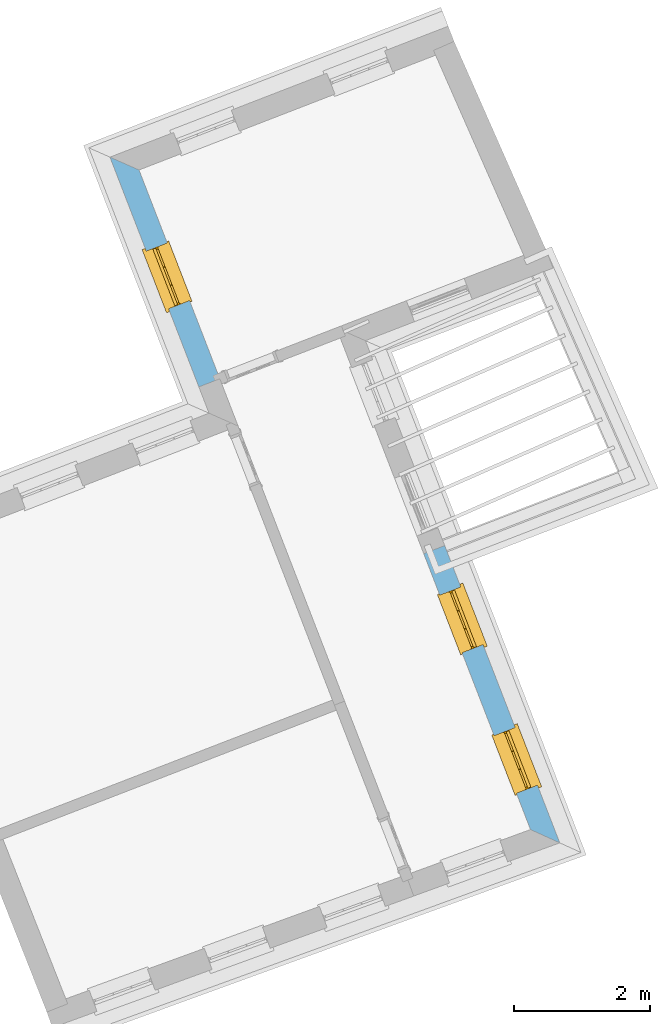
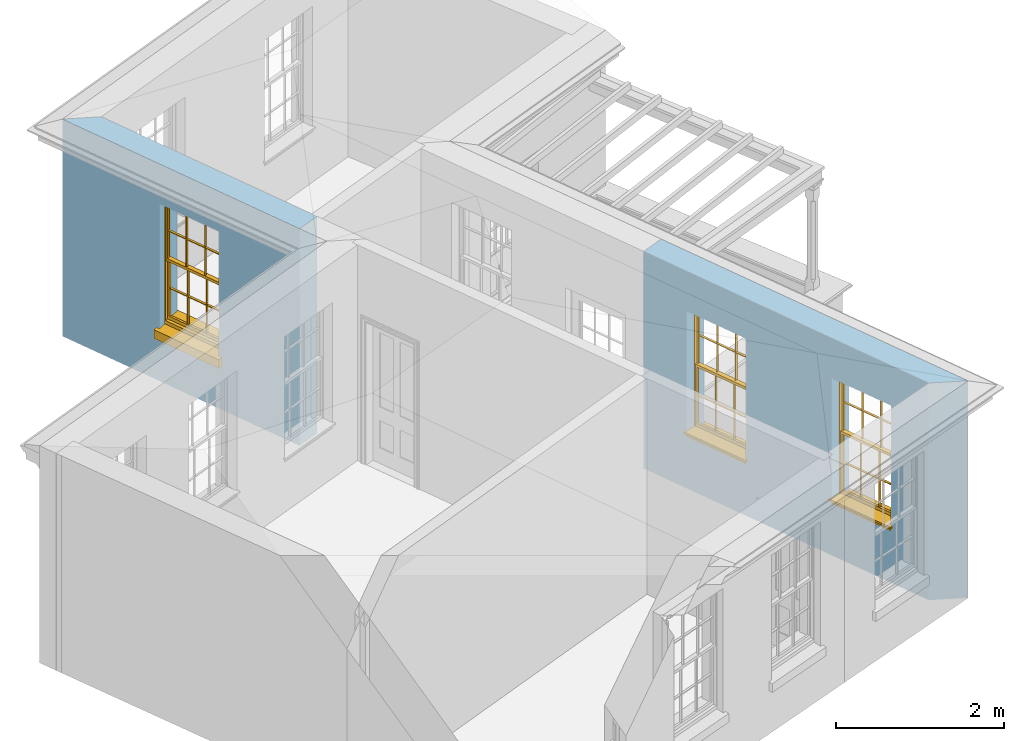
# One storey, part 7 of 11: 3 windows, 3 openings, plus 2 elements that do not belong to this part.
"""IFC2X3 building model written with IfcOpenShell, lengths in metres."""

from ifc_helpers import new_model, si_unit, frame, origin, place, context, subcontext, project, spatial, polyline, outline, extrude, faceted_brep, material, layer, layer_set, layer_usage, element, fill, save


model = new_model("IFC2X3")

# Units and contexts
model_context = context("Model", 3, world=origin())
body_context = subcontext(model_context, "Body", "Model", "MODEL_VIEW")
ifc_project = project(units=[si_unit("PLANEANGLEUNIT", "RADIAN"), si_unit("MASSUNIT", "GRAM", prefix="KILO"), si_unit("FORCEUNIT", "NEWTON", prefix="KILO"), si_unit("LENGTHUNIT", "METRE")], contexts=[model_context])

# Site, building, storey
site_placement = place(None, origin())
site = spatial("IfcSite", under=ifc_project, at=site_placement, CompositionType="ELEMENT")
building_placement = place(None, origin())
building = spatial("IfcBuilding", under=site, at=building_placement, Name="Building plot-5", CompositionType="ELEMENT")
storey_placement = place(None, frame((0.0, 0.0, 7.6)))
storey = spatial("IfcBuildingStorey", under=building, at=storey_placement, Name="Floor 1", CompositionType="ELEMENT", Elevation=7.6)

# Wall, opening, window
ifc_material = material(Name="Masonry")
ifc_layer = layer(ifc_material, 0.33, ventilated=False)
ifc_layer_set = layer_set([ifc_layer], Name="My Wall")
ifc_layer_usage = layer_usage(ifc_layer_set, "AXIS2", "NEGATIVE", 0.08)
wall_1_placement = place(storey_placement, origin())
wall_1 = element("IfcWallStandardCase", 1, at=wall_1_placement, inside=storey, material=ifc_layer_usage, Name="exterior", context=body_context, shape_type="SweptSolid", body=[
    extrude(outline(polyline([(58.9331084648426, 61.6885763134421), (58.5062551056088, 61.8772458915696), (59.8129029443682, 58.5005604091481), (60.1206644130489, 58.6196522997012), (58.9331084648426, 61.6885763134421)])), origin(), (0.0, 0.0, 1.0), 3.15),
])
opening_1_placement = place(storey_placement, frame((0.0, 0.0, 0.75)))
opening_1 = element("IfcOpeningElement", 2, at=opening_1_placement, cuts=wall_1, Name="Opening", ObjectType="Opening", context=body_context, shape_type="SweptSolid", body=[
    extrude(outline(polyline([(59.0404871344353, 60.4966646190395), (59.3688920447486, 59.6479890538898), (59.6766535134293, 59.767080944443), (59.348248603116, 60.6157565095927), (59.0404871344353, 60.4966646190395)])), origin(), (0.0, 0.0, 1.0), 1.82),
])
window_1_placement = place(storey_placement, frame((59.2736397622237, 60.5868857482464, 0.75), z_axis=(0.0, 0.0, 1.0), x_axis=(0.328404910313267, -0.848675565149684, 0.0)))
window_1 = element("IfcWindow", 3, at=window_1_placement, inside=storey, Name="bedroom outside window", OverallHeight=1.82, OverallWidth=0.91, context=body_context, shape_type="Brep", held_by="IfcProductRepresentation", body=[
    faceted_brep([(0.033125, -0.105, 0.975209), (0.01, -0.105, 0.975209), (0.033125, -0.105, 1.376042), (0.876875, -0.105, 0.975209), (0.876875, -0.105, 1.376042), (0.9, -0.105, 0.975209), (0.876875, -0.105, 1.386042), (0.876875, -0.105, 1.786875), (0.9, -0.105, 1.81), (0.033125, -0.105, 1.786875), (0.033125, -0.105, 1.386042), (0.01, -0.105, 1.81), (0.876875, -0.135, 1.376042), (0.876875, -0.135, 0.975209), (0.9, -0.135, 0.937083), (0.033125, -0.135, 1.786875), (0.01, -0.135, 1.81), (0.033125, -0.135, 1.386042), (0.01, -0.135, 0.937083), (0.033125, -0.135, 0.975209), (0.033125, -0.135, 1.376042), (0.876875, -0.135, 1.786875), (0.876875, -0.135, 1.386042), (0.9, -0.135, 1.81), (0.033125, -0.105, 0.937083), (0.01, -0.105, 0.937083), (0.033125, -0.105, 0.53625), (0.876875, -0.105, 0.937083), (0.876875, -0.105, 0.53625), (0.9, -0.105, 0.937083), (0.876875, -0.105, 0.52625), (0.876875, -0.105, 0.125417), (0.9, -0.105, 0.077167), (0.033125, -0.105, 0.125417), (0.033125, -0.105, 0.52625), (0.01, -0.105, 0.077167), (-0.0425, -0.25, 0.01), (-0.0425, -0.3, 0.001667), (0.0, -0.25, 0.01), (0.9525, -0.25, 0.01), (0.91, -0.25, 0.01), (0.9525, -0.3, 0.001667), (-0.02, 0.08, 0.077167), (0.0, 0.08, 0.077167), (-0.02, 0.11, 0.077167), (0.0, -0.06, 0.077167), (0.01, -0.06, 0.077167), (0.91, -0.06, 0.077167), (0.91, 0.08, 0.077167), (0.9, -0.06, 0.077167), (0.93, 0.08, 0.077167), (0.93, 0.11, 0.077167), (0.01, -0.075, 0.975209), (0.9, -0.075, 0.975209), (0.876875, -0.075, 0.125417), (0.876875, -0.075, 0.52625), (0.9, -0.075, 0.077167), (0.876875, -0.075, 0.53625), (0.876875, -0.075, 0.937083), (0.033125, -0.075, 0.125417), (0.01, -0.075, 0.077167), (0.033125, -0.075, 0.52625), (0.033125, -0.075, 0.937083), (0.033125, -0.075, 0.53625), (-0.02, 0.08, 0.052167), (-0.02, 0.11, 0.052167), (0.93, 0.11, 0.052167), (0.93, 0.08, 0.052167), (0.91, 0.08, 0.052167), (0.0, 0.08, 0.052167), (0.91, -0.15, 0.026667), (0.0, -0.15, 0.026667), (-0.0425, -0.3, -0.123333), (0.9525, -0.3, -0.123333), (-0.0425, -0.25, -0.123333), (0.9525, -0.25, -0.123333), (0.01, -0.06, 1.81), (0.9, -0.06, 1.81), (0.0, -0.06, 1.82), (0.91, -0.06, 1.82), (0.01, -0.15, 0.077167), (0.9, -0.15, 0.077167), (0.592292, -0.105, 0.125417), (0.592292, -0.075, 0.125417), (0.317708, -0.075, 0.125417), (0.317708, -0.105, 0.125417), (0.592292, -0.105, 0.53625), (0.317708, -0.105, 0.53625), (0.317708, -0.105, 0.52625), (0.592292, -0.105, 0.52625), (0.592292, -0.075, 0.53625), (0.317708, -0.075, 0.53625), (0.592292, -0.135, 1.386042), (0.592292, -0.105, 1.386042), (0.317708, -0.105, 1.386042), (0.317708, -0.135, 1.386042), (0.317708, -0.135, 1.376042), (0.592292, -0.135, 1.376042), (0.317708, -0.105, 1.376042), (0.592292, -0.105, 1.376042), (0.602292, -0.135, 1.376042), (0.592292, -0.135, 0.975209), (0.602292, -0.135, 0.975209), (0.602292, -0.105, 0.975209), (0.592292, -0.105, 0.975209), (0.602292, -0.105, 1.376042), (0.602292, -0.075, 0.53625), (0.602292, -0.105, 0.53625), (0.317708, -0.075, 0.52625), (0.307708, -0.075, 0.125417), (0.307708, -0.075, 0.52625), (0.602292, -0.075, 0.52625), (0.602292, -0.075, 0.125417), (0.592292, -0.075, 0.52625), (0.307708, -0.075, 0.53625), (0.317708, -0.075, 0.937083), (0.307708, -0.075, 0.937083), (0.602292, -0.075, 0.937083), (0.592292, -0.075, 0.937083), (0.307708, -0.105, 0.52625), (0.307708, -0.105, 0.125417), (0.307708, -0.105, 0.53625), (0.307708, -0.105, 0.937083), (0.592292, -0.105, 0.937083), (0.317708, -0.105, 0.937083), (0.602292, -0.105, 0.937083), (0.602292, -0.105, 0.52625), (0.602292, -0.105, 0.125417), (0.307708, -0.135, 1.386042), (0.307708, -0.135, 1.376042), (0.307708, -0.135, 0.975209), (0.317708, -0.135, 0.975209), (0.317708, -0.135, 1.786875), (0.307708, -0.135, 1.786875), (0.602292, -0.135, 1.786875), (0.592292, -0.135, 1.786875), (0.602292, -0.135, 1.386042), (0.602292, -0.105, 1.386042), (0.307708, -0.105, 1.386042), (0.307708, -0.105, 1.786875), (0.317708, -0.105, 1.786875), (0.592292, -0.105, 1.786875), (0.602292, -0.105, 1.786875), (0.307708, -0.105, 1.376042), (0.317708, -0.105, 0.975209), (0.307708, -0.105, 0.975209), (0.91, -0.15, 1.82), (0.9, -0.15, 1.81), (0.01, -0.15, 1.81), (0.0, -0.15, 1.82), (0.91, -0.25, 0.0), (0.0, -0.25, 0.0), (0.91, 0.08, 0.0), (0.0, 0.08, 0.0)], [[[0, 1, 2]], [[3, 4, 5]], [[6, 7, 8]], [[9, 10, 11]], [[12, 13, 14]], [[15, 16, 17]], [[18, 19, 20]], [[21, 22, 23]], [[24, 25, 26]], [[27, 28, 29]], [[30, 31, 32]], [[33, 34, 35]], [[14, 27, 29]], [[25, 24, 18]], [[36, 37, 38]], [[39, 40, 41]], [[42, 43, 44]], [[45, 46, 43]], [[47, 48, 49]], [[50, 51, 48]], [[1, 0, 52]], [[5, 53, 3]], [[54, 55, 56]], [[57, 58, 53]], [[59, 60, 61]], [[62, 63, 52]], [[48, 43, 46, 49]], [[51, 44, 43, 48]], [[64, 42, 44, 65]], [[65, 44, 51, 66]], [[66, 51, 50, 67]], [[65, 66, 68, 69]], [[60, 56, 49, 46]], [[70, 71, 38, 40]], [[37, 41, 40, 38]], [[37, 72, 73, 41]], [[74, 75, 73, 72]], [[8, 11, 76, 77]], [[76, 78, 79, 77]], [[32, 35, 80, 81]], [[81, 80, 71, 70]], [[82, 83, 84, 85]], [[86, 87, 88, 89]], [[86, 90, 91, 87]], [[92, 93, 94, 95]], [[92, 95, 96, 97]], [[96, 98, 99, 97]], [[100, 97, 101, 102]], [[103, 104, 99, 105]], [[97, 99, 104, 101]], [[102, 103, 105, 100]], [[28, 57, 106, 107]], [[108, 84, 109, 110]], [[111, 112, 83, 113]], [[114, 110, 61, 63]], [[90, 113, 108, 91]], [[115, 91, 114, 116]], [[117, 106, 90, 118]], [[111, 106, 57, 55]], [[119, 110, 109, 120]], [[34, 61, 110, 119]], [[89, 113, 83, 82]], [[88, 108, 113, 89]], [[85, 84, 108, 88]], [[121, 114, 63, 26]], [[122, 116, 114, 121]], [[123, 118, 90, 86]], [[87, 91, 115, 124]], [[107, 106, 117, 125]], [[126, 111, 55, 30]], [[127, 112, 111, 126]], [[126, 30, 28, 107]], [[88, 119, 120, 85]], [[126, 89, 82, 127]], [[125, 123, 86, 107]], [[121, 26, 34, 119]], [[124, 122, 121, 87]], [[128, 17, 20, 129]], [[96, 129, 130, 131]], [[132, 133, 128, 95]], [[134, 135, 92, 136]], [[100, 12, 22, 136]], [[137, 6, 4, 105]], [[94, 138, 139, 140]], [[137, 93, 141, 142]], [[99, 98, 94, 93]], [[143, 2, 10, 138]], [[144, 145, 143, 98]], [[129, 143, 145, 130]], [[20, 2, 143, 129]], [[131, 144, 98, 96]], [[128, 138, 10, 17]], [[133, 139, 138, 128]], [[135, 141, 93, 92]], [[95, 94, 140, 132]], [[22, 6, 137, 136]], [[136, 137, 142, 134]], [[100, 105, 4, 12]], [[107, 86, 89, 126]], [[106, 111, 113, 90]], [[91, 108, 110, 114]], [[87, 121, 119, 88]], [[97, 100, 136, 92]], [[129, 96, 95, 128]], [[98, 143, 138, 94]], [[105, 99, 93, 137]], [[131, 101, 104, 144]], [[124, 115, 118, 123]], [[132, 140, 141, 135]], [[120, 109, 59, 33]], [[15, 9, 139, 133]], [[134, 142, 7, 21]], [[31, 54, 112, 127]], [[36, 74, 72, 37]], [[39, 41, 73, 75]], [[18, 14, 101, 131]], [[23, 16, 132, 135]], [[83, 56, 60, 84]], [[52, 53, 118, 115]], [[53, 52, 144, 104]], [[11, 8, 141, 140]], [[14, 18, 124, 123]], [[2, 1, 11, 10]], [[8, 5, 4, 6]], [[57, 53, 56, 55]], [[60, 52, 63, 61]], [[26, 25, 35, 34]], [[32, 29, 28, 30]], [[14, 23, 22, 12]], [[18, 20, 17, 16]], [[19, 0, 2, 20]], [[17, 10, 9, 15]], [[12, 4, 3, 13]], [[21, 7, 6, 22]], [[27, 58, 57, 28]], [[30, 55, 54, 31]], [[33, 59, 61, 34]], [[26, 63, 62, 24]], [[5, 8, 77, 53]], [[76, 11, 1, 52]], [[46, 45, 78, 76]], [[49, 77, 79, 47]], [[70, 146, 147, 81]], [[71, 80, 148, 149]], [[19, 130, 145, 0]], [[102, 13, 3, 103]], [[116, 122, 24, 62]], [[29, 32, 81, 14]], [[80, 35, 25, 18]], [[60, 46, 76, 52]], [[77, 49, 56, 53]], [[23, 14, 81, 147]], [[16, 148, 80, 18]], [[35, 85, 120]], [[120, 33, 35]], [[127, 82, 32]], [[32, 31, 127]], [[32, 82, 85, 35]], [[102, 101, 14]], [[14, 13, 102]], [[18, 131, 130]], [[130, 19, 18]], [[134, 21, 23]], [[23, 135, 134]], [[16, 15, 133]], [[133, 132, 16]], [[11, 140, 139]], [[139, 9, 11]], [[142, 141, 8]], [[8, 7, 142]], [[23, 147, 148, 16]], [[146, 149, 148, 147]], [[52, 115, 116]], [[116, 62, 52]], [[118, 53, 117]], [[58, 117, 53]], [[27, 125, 117, 58]], [[56, 83, 112]], [[112, 54, 56]], [[109, 84, 60]], [[60, 59, 109]], [[125, 27, 14]], [[14, 123, 125]], [[122, 124, 18]], [[18, 24, 122]], [[145, 144, 52]], [[52, 0, 145]], [[103, 3, 53]], [[53, 104, 103]], [[79, 78, 149, 146]], [[78, 45, 71, 149]], [[146, 70, 47, 79]], [[150, 75, 74, 151]], [[68, 66, 67]], [[48, 68, 67, 50]], [[69, 64, 65]], [[42, 64, 69, 43]], [[69, 68, 152, 153]], [[70, 68, 48, 47]], [[150, 152, 68, 70]], [[43, 69, 71, 45]], [[69, 153, 151, 71]], [[152, 150, 151, 153]], [[38, 151, 74, 36]], [[71, 151, 38]], [[39, 75, 150, 40]], [[40, 150, 70]]]),
])
fill(opening_1, window_1)

# Wall, openings, windows
wall_2_placement = place(storey_placement, origin())
wall_2 = element("IfcWallStandardCase", 4, at=wall_2_placement, inside=storey, material=ifc_layer_usage, Name="exterior", context=body_context, shape_type="SweptSolid", body=[
    extrude(outline(polyline([(64.6874687237686, 51.9939267924886), (65.1167215345807, 51.7990564668682), (63.4260314383826, 56.1681975114254), (63.1182699697019, 56.0491056208722), (64.6874687237686, 51.9939267924886)])), origin(), (0.0, 0.0, 1.0), 3.15),
])
opening_2_placement = place(storey_placement, frame((0.0, 0.0, 0.75)))
opening_2 = element("IfcOpeningElement", 5, at=opening_2_placement, cuts=wall_2, Name="Opening", ObjectType="Opening", context=body_context, shape_type="SweptSolid", body=[
    extrude(outline(polyline([(64.7892222940222, 52.6453915682585), (64.4608173837089, 53.4940671334082), (64.1530559150283, 53.374975242855), (64.4814608253416, 52.5262996777054), (64.7892222940222, 52.6453915682585)])), origin(), (0.0, 0.0, 1.0), 1.82),
])
opening_3_placement = place(storey_placement, frame((0.0, 0.0, 0.75)))
opening_3 = element("IfcOpeningElement", 6, at=opening_3_placement, cuts=wall_2, Name="Opening", ObjectType="Opening", context=body_context, shape_type="SweptSolid", body=[
    extrude(outline(polyline([(63.9898966937002, 54.7110370086532), (63.6614917833869, 55.5597125738029), (63.3537303147063, 55.4406206832497), (63.6821352250196, 54.5919451181), (63.9898966937002, 54.7110370086532)])), origin(), (0.0, 0.0, 1.0), 1.82),
])
window_2_placement = place(storey_placement, frame((64.5560696662338, 52.5551704390516, 0.75), z_axis=(0.0, 0.0, 1.0), x_axis=(-0.328404910313296, 0.848675565149676, 0.0)))
window_2 = element("IfcWindow", 7, at=window_2_placement, inside=storey, Name="circulation outside window", OverallHeight=1.82, OverallWidth=0.91, context=body_context, shape_type="Brep", held_by="IfcProductRepresentation", body=[
    faceted_brep([(0.033125, -0.105, 0.975209), (0.01, -0.105, 0.975209), (0.033125, -0.105, 1.376042), (0.876875, -0.105, 0.975209), (0.876875, -0.105, 1.376042), (0.9, -0.105, 0.975209), (0.876875, -0.105, 1.386042), (0.876875, -0.105, 1.786875), (0.9, -0.105, 1.81), (0.033125, -0.105, 1.786875), (0.033125, -0.105, 1.386042), (0.01, -0.105, 1.81), (0.876875, -0.135, 1.376042), (0.876875, -0.135, 0.975209), (0.9, -0.135, 0.937083), (0.033125, -0.135, 1.786875), (0.01, -0.135, 1.81), (0.033125, -0.135, 1.386042), (0.01, -0.135, 0.937083), (0.033125, -0.135, 0.975209), (0.033125, -0.135, 1.376042), (0.876875, -0.135, 1.786875), (0.876875, -0.135, 1.386042), (0.9, -0.135, 1.81), (0.033125, -0.105, 0.937083), (0.01, -0.105, 0.937083), (0.033125, -0.105, 0.53625), (0.876875, -0.105, 0.937083), (0.876875, -0.105, 0.53625), (0.9, -0.105, 0.937083), (0.876875, -0.105, 0.52625), (0.876875, -0.105, 0.125417), (0.9, -0.105, 0.077167), (0.033125, -0.105, 0.125417), (0.033125, -0.105, 0.52625), (0.01, -0.105, 0.077167), (-0.0425, -0.25, 0.01), (-0.0425, -0.3, 0.001667), (0.0, -0.25, 0.01), (0.9525, -0.25, 0.01), (0.91, -0.25, 0.01), (0.9525, -0.3, 0.001667), (-0.02, 0.08, 0.077167), (0.0, 0.08, 0.077167), (-0.02, 0.11, 0.077167), (0.0, -0.06, 0.077167), (0.01, -0.06, 0.077167), (0.91, -0.06, 0.077167), (0.91, 0.08, 0.077167), (0.9, -0.06, 0.077167), (0.93, 0.08, 0.077167), (0.93, 0.11, 0.077167), (0.01, -0.075, 0.975209), (0.9, -0.075, 0.975209), (0.876875, -0.075, 0.125417), (0.876875, -0.075, 0.52625), (0.9, -0.075, 0.077167), (0.876875, -0.075, 0.53625), (0.876875, -0.075, 0.937083), (0.033125, -0.075, 0.125417), (0.01, -0.075, 0.077167), (0.033125, -0.075, 0.52625), (0.033125, -0.075, 0.937083), (0.033125, -0.075, 0.53625), (-0.02, 0.08, 0.052167), (-0.02, 0.11, 0.052167), (0.93, 0.11, 0.052167), (0.93, 0.08, 0.052167), (0.91, 0.08, 0.052167), (0.0, 0.08, 0.052167), (0.91, -0.15, 0.026667), (0.0, -0.15, 0.026667), (-0.0425, -0.3, -0.123333), (0.9525, -0.3, -0.123333), (-0.0425, -0.25, -0.123333), (0.9525, -0.25, -0.123333), (0.01, -0.06, 1.81), (0.9, -0.06, 1.81), (0.0, -0.06, 1.82), (0.91, -0.06, 1.82), (0.01, -0.15, 0.077167), (0.9, -0.15, 0.077167), (0.592292, -0.105, 0.125417), (0.592292, -0.075, 0.125417), (0.317708, -0.075, 0.125417), (0.317708, -0.105, 0.125417), (0.592292, -0.105, 0.53625), (0.317708, -0.105, 0.53625), (0.317708, -0.105, 0.52625), (0.592292, -0.105, 0.52625), (0.592292, -0.075, 0.53625), (0.317708, -0.075, 0.53625), (0.592292, -0.135, 1.386042), (0.592292, -0.105, 1.386042), (0.317708, -0.105, 1.386042), (0.317708, -0.135, 1.386042), (0.317708, -0.135, 1.376042), (0.592292, -0.135, 1.376042), (0.317708, -0.105, 1.376042), (0.592292, -0.105, 1.376042), (0.602292, -0.135, 1.376042), (0.592292, -0.135, 0.975209), (0.602292, -0.135, 0.975209), (0.602292, -0.105, 0.975209), (0.592292, -0.105, 0.975209), (0.602292, -0.105, 1.376042), (0.602292, -0.075, 0.53625), (0.602292, -0.105, 0.53625), (0.317708, -0.075, 0.52625), (0.307708, -0.075, 0.125417), (0.307708, -0.075, 0.52625), (0.602292, -0.075, 0.52625), (0.602292, -0.075, 0.125417), (0.592292, -0.075, 0.52625), (0.307708, -0.075, 0.53625), (0.317708, -0.075, 0.937083), (0.307708, -0.075, 0.937083), (0.602292, -0.075, 0.937083), (0.592292, -0.075, 0.937083), (0.307708, -0.105, 0.52625), (0.307708, -0.105, 0.125417), (0.307708, -0.105, 0.53625), (0.307708, -0.105, 0.937083), (0.592292, -0.105, 0.937083), (0.317708, -0.105, 0.937083), (0.602292, -0.105, 0.937083), (0.602292, -0.105, 0.52625), (0.602292, -0.105, 0.125417), (0.307708, -0.135, 1.386042), (0.307708, -0.135, 1.376042), (0.307708, -0.135, 0.975209), (0.317708, -0.135, 0.975209), (0.317708, -0.135, 1.786875), (0.307708, -0.135, 1.786875), (0.602292, -0.135, 1.786875), (0.592292, -0.135, 1.786875), (0.602292, -0.135, 1.386042), (0.602292, -0.105, 1.386042), (0.307708, -0.105, 1.386042), (0.307708, -0.105, 1.786875), (0.317708, -0.105, 1.786875), (0.592292, -0.105, 1.786875), (0.602292, -0.105, 1.786875), (0.307708, -0.105, 1.376042), (0.317708, -0.105, 0.975209), (0.307708, -0.105, 0.975209), (0.91, -0.15, 1.82), (0.9, -0.15, 1.81), (0.01, -0.15, 1.81), (0.0, -0.15, 1.82), (0.91, -0.25, 0.0), (0.0, -0.25, 0.0), (0.91, 0.08, 0.0), (0.0, 0.08, 0.0)], [[[0, 1, 2]], [[3, 4, 5]], [[6, 7, 8]], [[9, 10, 11]], [[12, 13, 14]], [[15, 16, 17]], [[18, 19, 20]], [[21, 22, 23]], [[24, 25, 26]], [[27, 28, 29]], [[30, 31, 32]], [[33, 34, 35]], [[14, 27, 29]], [[25, 24, 18]], [[36, 37, 38]], [[39, 40, 41]], [[42, 43, 44]], [[45, 46, 43]], [[47, 48, 49]], [[50, 51, 48]], [[1, 0, 52]], [[5, 53, 3]], [[54, 55, 56]], [[57, 58, 53]], [[59, 60, 61]], [[62, 63, 52]], [[48, 43, 46, 49]], [[51, 44, 43, 48]], [[64, 42, 44, 65]], [[65, 44, 51, 66]], [[66, 51, 50, 67]], [[65, 66, 68, 69]], [[60, 56, 49, 46]], [[70, 71, 38, 40]], [[37, 41, 40, 38]], [[37, 72, 73, 41]], [[74, 75, 73, 72]], [[8, 11, 76, 77]], [[76, 78, 79, 77]], [[32, 35, 80, 81]], [[81, 80, 71, 70]], [[82, 83, 84, 85]], [[86, 87, 88, 89]], [[86, 90, 91, 87]], [[92, 93, 94, 95]], [[92, 95, 96, 97]], [[96, 98, 99, 97]], [[100, 97, 101, 102]], [[103, 104, 99, 105]], [[97, 99, 104, 101]], [[102, 103, 105, 100]], [[28, 57, 106, 107]], [[108, 84, 109, 110]], [[111, 112, 83, 113]], [[114, 110, 61, 63]], [[90, 113, 108, 91]], [[115, 91, 114, 116]], [[117, 106, 90, 118]], [[111, 106, 57, 55]], [[119, 110, 109, 120]], [[34, 61, 110, 119]], [[89, 113, 83, 82]], [[88, 108, 113, 89]], [[85, 84, 108, 88]], [[121, 114, 63, 26]], [[122, 116, 114, 121]], [[123, 118, 90, 86]], [[87, 91, 115, 124]], [[107, 106, 117, 125]], [[126, 111, 55, 30]], [[127, 112, 111, 126]], [[126, 30, 28, 107]], [[88, 119, 120, 85]], [[126, 89, 82, 127]], [[125, 123, 86, 107]], [[121, 26, 34, 119]], [[124, 122, 121, 87]], [[128, 17, 20, 129]], [[96, 129, 130, 131]], [[132, 133, 128, 95]], [[134, 135, 92, 136]], [[100, 12, 22, 136]], [[137, 6, 4, 105]], [[94, 138, 139, 140]], [[137, 93, 141, 142]], [[99, 98, 94, 93]], [[143, 2, 10, 138]], [[144, 145, 143, 98]], [[129, 143, 145, 130]], [[20, 2, 143, 129]], [[131, 144, 98, 96]], [[128, 138, 10, 17]], [[133, 139, 138, 128]], [[135, 141, 93, 92]], [[95, 94, 140, 132]], [[22, 6, 137, 136]], [[136, 137, 142, 134]], [[100, 105, 4, 12]], [[107, 86, 89, 126]], [[106, 111, 113, 90]], [[91, 108, 110, 114]], [[87, 121, 119, 88]], [[97, 100, 136, 92]], [[129, 96, 95, 128]], [[98, 143, 138, 94]], [[105, 99, 93, 137]], [[131, 101, 104, 144]], [[124, 115, 118, 123]], [[132, 140, 141, 135]], [[120, 109, 59, 33]], [[15, 9, 139, 133]], [[134, 142, 7, 21]], [[31, 54, 112, 127]], [[36, 74, 72, 37]], [[39, 41, 73, 75]], [[18, 14, 101, 131]], [[23, 16, 132, 135]], [[83, 56, 60, 84]], [[52, 53, 118, 115]], [[53, 52, 144, 104]], [[11, 8, 141, 140]], [[14, 18, 124, 123]], [[2, 1, 11, 10]], [[8, 5, 4, 6]], [[57, 53, 56, 55]], [[60, 52, 63, 61]], [[26, 25, 35, 34]], [[32, 29, 28, 30]], [[14, 23, 22, 12]], [[18, 20, 17, 16]], [[19, 0, 2, 20]], [[17, 10, 9, 15]], [[12, 4, 3, 13]], [[21, 7, 6, 22]], [[27, 58, 57, 28]], [[30, 55, 54, 31]], [[33, 59, 61, 34]], [[26, 63, 62, 24]], [[5, 8, 77, 53]], [[76, 11, 1, 52]], [[46, 45, 78, 76]], [[49, 77, 79, 47]], [[70, 146, 147, 81]], [[71, 80, 148, 149]], [[19, 130, 145, 0]], [[102, 13, 3, 103]], [[116, 122, 24, 62]], [[29, 32, 81, 14]], [[80, 35, 25, 18]], [[60, 46, 76, 52]], [[77, 49, 56, 53]], [[23, 14, 81, 147]], [[16, 148, 80, 18]], [[35, 85, 120]], [[120, 33, 35]], [[127, 82, 32]], [[32, 31, 127]], [[32, 82, 85, 35]], [[102, 101, 14]], [[14, 13, 102]], [[18, 131, 130]], [[130, 19, 18]], [[134, 21, 23]], [[23, 135, 134]], [[16, 15, 133]], [[133, 132, 16]], [[11, 140, 139]], [[139, 9, 11]], [[142, 141, 8]], [[8, 7, 142]], [[23, 147, 148, 16]], [[146, 149, 148, 147]], [[52, 115, 116]], [[116, 62, 52]], [[118, 53, 117]], [[58, 117, 53]], [[27, 125, 117, 58]], [[56, 83, 112]], [[112, 54, 56]], [[109, 84, 60]], [[60, 59, 109]], [[125, 27, 14]], [[14, 123, 125]], [[122, 124, 18]], [[18, 24, 122]], [[145, 144, 52]], [[52, 0, 145]], [[103, 3, 53]], [[53, 104, 103]], [[79, 78, 149, 146]], [[78, 45, 71, 149]], [[146, 70, 47, 79]], [[150, 75, 74, 151]], [[68, 66, 67]], [[48, 68, 67, 50]], [[69, 64, 65]], [[42, 64, 69, 43]], [[69, 68, 152, 153]], [[70, 68, 48, 47]], [[150, 152, 68, 70]], [[43, 69, 71, 45]], [[69, 153, 151, 71]], [[152, 150, 151, 153]], [[38, 151, 74, 36]], [[71, 151, 38]], [[39, 75, 150, 40]], [[40, 150, 70]]]),
])
fill(opening_2, window_2)
window_3_placement = place(storey_placement, frame((63.7567440659118, 54.6208158794462, 0.75), z_axis=(0.0, 0.0, 1.0), x_axis=(-0.328404910313296, 0.848675565149676, 0.0)))
window_3 = element("IfcWindow", 8, at=window_3_placement, inside=storey, Name="circulation outside window", OverallHeight=1.82, OverallWidth=0.91, context=body_context, shape_type="Brep", held_by="IfcProductRepresentation", body=[
    faceted_brep([(0.033125, -0.105, 0.975209), (0.01, -0.105, 0.975209), (0.033125, -0.105, 1.376042), (0.876875, -0.105, 0.975209), (0.876875, -0.105, 1.376042), (0.9, -0.105, 0.975209), (0.876875, -0.105, 1.386042), (0.876875, -0.105, 1.786875), (0.9, -0.105, 1.81), (0.033125, -0.105, 1.786875), (0.033125, -0.105, 1.386042), (0.01, -0.105, 1.81), (0.876875, -0.135, 1.376042), (0.876875, -0.135, 0.975209), (0.9, -0.135, 0.937083), (0.033125, -0.135, 1.786875), (0.01, -0.135, 1.81), (0.033125, -0.135, 1.386042), (0.01, -0.135, 0.937083), (0.033125, -0.135, 0.975209), (0.033125, -0.135, 1.376042), (0.876875, -0.135, 1.786875), (0.876875, -0.135, 1.386042), (0.9, -0.135, 1.81), (0.033125, -0.105, 0.937083), (0.01, -0.105, 0.937083), (0.033125, -0.105, 0.53625), (0.876875, -0.105, 0.937083), (0.876875, -0.105, 0.53625), (0.9, -0.105, 0.937083), (0.876875, -0.105, 0.52625), (0.876875, -0.105, 0.125417), (0.9, -0.105, 0.077167), (0.033125, -0.105, 0.125417), (0.033125, -0.105, 0.52625), (0.01, -0.105, 0.077167), (-0.0425, -0.25, 0.01), (-0.0425, -0.3, 0.001667), (0.0, -0.25, 0.01), (0.9525, -0.25, 0.01), (0.91, -0.25, 0.01), (0.9525, -0.3, 0.001667), (-0.02, 0.08, 0.077167), (0.0, 0.08, 0.077167), (-0.02, 0.11, 0.077167), (0.0, -0.06, 0.077167), (0.01, -0.06, 0.077167), (0.91, -0.06, 0.077167), (0.91, 0.08, 0.077167), (0.9, -0.06, 0.077167), (0.93, 0.08, 0.077167), (0.93, 0.11, 0.077167), (0.01, -0.075, 0.975209), (0.9, -0.075, 0.975209), (0.876875, -0.075, 0.125417), (0.876875, -0.075, 0.52625), (0.9, -0.075, 0.077167), (0.876875, -0.075, 0.53625), (0.876875, -0.075, 0.937083), (0.033125, -0.075, 0.125417), (0.01, -0.075, 0.077167), (0.033125, -0.075, 0.52625), (0.033125, -0.075, 0.937083), (0.033125, -0.075, 0.53625), (-0.02, 0.08, 0.052167), (-0.02, 0.11, 0.052167), (0.93, 0.11, 0.052167), (0.93, 0.08, 0.052167), (0.91, 0.08, 0.052167), (0.0, 0.08, 0.052167), (0.91, -0.15, 0.026667), (0.0, -0.15, 0.026667), (-0.0425, -0.3, -0.123333), (0.9525, -0.3, -0.123333), (-0.0425, -0.25, -0.123333), (0.9525, -0.25, -0.123333), (0.01, -0.06, 1.81), (0.9, -0.06, 1.81), (0.0, -0.06, 1.82), (0.91, -0.06, 1.82), (0.01, -0.15, 0.077167), (0.9, -0.15, 0.077167), (0.592292, -0.105, 0.125417), (0.592292, -0.075, 0.125417), (0.317708, -0.075, 0.125417), (0.317708, -0.105, 0.125417), (0.592292, -0.105, 0.53625), (0.317708, -0.105, 0.53625), (0.317708, -0.105, 0.52625), (0.592292, -0.105, 0.52625), (0.592292, -0.075, 0.53625), (0.317708, -0.075, 0.53625), (0.592292, -0.135, 1.386042), (0.592292, -0.105, 1.386042), (0.317708, -0.105, 1.386042), (0.317708, -0.135, 1.386042), (0.317708, -0.135, 1.376042), (0.592292, -0.135, 1.376042), (0.317708, -0.105, 1.376042), (0.592292, -0.105, 1.376042), (0.602292, -0.135, 1.376042), (0.592292, -0.135, 0.975209), (0.602292, -0.135, 0.975209), (0.602292, -0.105, 0.975209), (0.592292, -0.105, 0.975209), (0.602292, -0.105, 1.376042), (0.602292, -0.075, 0.53625), (0.602292, -0.105, 0.53625), (0.317708, -0.075, 0.52625), (0.307708, -0.075, 0.125417), (0.307708, -0.075, 0.52625), (0.602292, -0.075, 0.52625), (0.602292, -0.075, 0.125417), (0.592292, -0.075, 0.52625), (0.307708, -0.075, 0.53625), (0.317708, -0.075, 0.937083), (0.307708, -0.075, 0.937083), (0.602292, -0.075, 0.937083), (0.592292, -0.075, 0.937083), (0.307708, -0.105, 0.52625), (0.307708, -0.105, 0.125417), (0.307708, -0.105, 0.53625), (0.307708, -0.105, 0.937083), (0.592292, -0.105, 0.937083), (0.317708, -0.105, 0.937083), (0.602292, -0.105, 0.937083), (0.602292, -0.105, 0.52625), (0.602292, -0.105, 0.125417), (0.307708, -0.135, 1.386042), (0.307708, -0.135, 1.376042), (0.307708, -0.135, 0.975209), (0.317708, -0.135, 0.975209), (0.317708, -0.135, 1.786875), (0.307708, -0.135, 1.786875), (0.602292, -0.135, 1.786875), (0.592292, -0.135, 1.786875), (0.602292, -0.135, 1.386042), (0.602292, -0.105, 1.386042), (0.307708, -0.105, 1.386042), (0.307708, -0.105, 1.786875), (0.317708, -0.105, 1.786875), (0.592292, -0.105, 1.786875), (0.602292, -0.105, 1.786875), (0.307708, -0.105, 1.376042), (0.317708, -0.105, 0.975209), (0.307708, -0.105, 0.975209), (0.91, -0.15, 1.82), (0.9, -0.15, 1.81), (0.01, -0.15, 1.81), (0.0, -0.15, 1.82), (0.91, -0.25, 0.0), (0.0, -0.25, 0.0), (0.91, 0.08, 0.0), (0.0, 0.08, 0.0)], [[[0, 1, 2]], [[3, 4, 5]], [[6, 7, 8]], [[9, 10, 11]], [[12, 13, 14]], [[15, 16, 17]], [[18, 19, 20]], [[21, 22, 23]], [[24, 25, 26]], [[27, 28, 29]], [[30, 31, 32]], [[33, 34, 35]], [[14, 27, 29]], [[25, 24, 18]], [[36, 37, 38]], [[39, 40, 41]], [[42, 43, 44]], [[45, 46, 43]], [[47, 48, 49]], [[50, 51, 48]], [[1, 0, 52]], [[5, 53, 3]], [[54, 55, 56]], [[57, 58, 53]], [[59, 60, 61]], [[62, 63, 52]], [[48, 43, 46, 49]], [[51, 44, 43, 48]], [[64, 42, 44, 65]], [[65, 44, 51, 66]], [[66, 51, 50, 67]], [[65, 66, 68, 69]], [[60, 56, 49, 46]], [[70, 71, 38, 40]], [[37, 41, 40, 38]], [[37, 72, 73, 41]], [[74, 75, 73, 72]], [[8, 11, 76, 77]], [[76, 78, 79, 77]], [[32, 35, 80, 81]], [[81, 80, 71, 70]], [[82, 83, 84, 85]], [[86, 87, 88, 89]], [[86, 90, 91, 87]], [[92, 93, 94, 95]], [[92, 95, 96, 97]], [[96, 98, 99, 97]], [[100, 97, 101, 102]], [[103, 104, 99, 105]], [[97, 99, 104, 101]], [[102, 103, 105, 100]], [[28, 57, 106, 107]], [[108, 84, 109, 110]], [[111, 112, 83, 113]], [[114, 110, 61, 63]], [[90, 113, 108, 91]], [[115, 91, 114, 116]], [[117, 106, 90, 118]], [[111, 106, 57, 55]], [[119, 110, 109, 120]], [[34, 61, 110, 119]], [[89, 113, 83, 82]], [[88, 108, 113, 89]], [[85, 84, 108, 88]], [[121, 114, 63, 26]], [[122, 116, 114, 121]], [[123, 118, 90, 86]], [[87, 91, 115, 124]], [[107, 106, 117, 125]], [[126, 111, 55, 30]], [[127, 112, 111, 126]], [[126, 30, 28, 107]], [[88, 119, 120, 85]], [[126, 89, 82, 127]], [[125, 123, 86, 107]], [[121, 26, 34, 119]], [[124, 122, 121, 87]], [[128, 17, 20, 129]], [[96, 129, 130, 131]], [[132, 133, 128, 95]], [[134, 135, 92, 136]], [[100, 12, 22, 136]], [[137, 6, 4, 105]], [[94, 138, 139, 140]], [[137, 93, 141, 142]], [[99, 98, 94, 93]], [[143, 2, 10, 138]], [[144, 145, 143, 98]], [[129, 143, 145, 130]], [[20, 2, 143, 129]], [[131, 144, 98, 96]], [[128, 138, 10, 17]], [[133, 139, 138, 128]], [[135, 141, 93, 92]], [[95, 94, 140, 132]], [[22, 6, 137, 136]], [[136, 137, 142, 134]], [[100, 105, 4, 12]], [[107, 86, 89, 126]], [[106, 111, 113, 90]], [[91, 108, 110, 114]], [[87, 121, 119, 88]], [[97, 100, 136, 92]], [[129, 96, 95, 128]], [[98, 143, 138, 94]], [[105, 99, 93, 137]], [[131, 101, 104, 144]], [[124, 115, 118, 123]], [[132, 140, 141, 135]], [[120, 109, 59, 33]], [[15, 9, 139, 133]], [[134, 142, 7, 21]], [[31, 54, 112, 127]], [[36, 74, 72, 37]], [[39, 41, 73, 75]], [[18, 14, 101, 131]], [[23, 16, 132, 135]], [[83, 56, 60, 84]], [[52, 53, 118, 115]], [[53, 52, 144, 104]], [[11, 8, 141, 140]], [[14, 18, 124, 123]], [[2, 1, 11, 10]], [[8, 5, 4, 6]], [[57, 53, 56, 55]], [[60, 52, 63, 61]], [[26, 25, 35, 34]], [[32, 29, 28, 30]], [[14, 23, 22, 12]], [[18, 20, 17, 16]], [[19, 0, 2, 20]], [[17, 10, 9, 15]], [[12, 4, 3, 13]], [[21, 7, 6, 22]], [[27, 58, 57, 28]], [[30, 55, 54, 31]], [[33, 59, 61, 34]], [[26, 63, 62, 24]], [[5, 8, 77, 53]], [[76, 11, 1, 52]], [[46, 45, 78, 76]], [[49, 77, 79, 47]], [[70, 146, 147, 81]], [[71, 80, 148, 149]], [[19, 130, 145, 0]], [[102, 13, 3, 103]], [[116, 122, 24, 62]], [[29, 32, 81, 14]], [[80, 35, 25, 18]], [[60, 46, 76, 52]], [[77, 49, 56, 53]], [[23, 14, 81, 147]], [[16, 148, 80, 18]], [[35, 85, 120]], [[120, 33, 35]], [[127, 82, 32]], [[32, 31, 127]], [[32, 82, 85, 35]], [[102, 101, 14]], [[14, 13, 102]], [[18, 131, 130]], [[130, 19, 18]], [[134, 21, 23]], [[23, 135, 134]], [[16, 15, 133]], [[133, 132, 16]], [[11, 140, 139]], [[139, 9, 11]], [[142, 141, 8]], [[8, 7, 142]], [[23, 147, 148, 16]], [[146, 149, 148, 147]], [[52, 115, 116]], [[116, 62, 52]], [[118, 53, 117]], [[58, 117, 53]], [[27, 125, 117, 58]], [[56, 83, 112]], [[112, 54, 56]], [[109, 84, 60]], [[60, 59, 109]], [[125, 27, 14]], [[14, 123, 125]], [[122, 124, 18]], [[18, 24, 122]], [[145, 144, 52]], [[52, 0, 145]], [[103, 3, 53]], [[53, 104, 103]], [[79, 78, 149, 146]], [[78, 45, 71, 149]], [[146, 70, 47, 79]], [[150, 75, 74, 151]], [[68, 66, 67]], [[48, 68, 67, 50]], [[69, 64, 65]], [[42, 64, 69, 43]], [[69, 68, 152, 153]], [[70, 68, 48, 47]], [[150, 152, 68, 70]], [[43, 69, 71, 45]], [[69, 153, 151, 71]], [[152, 150, 151, 153]], [[38, 151, 74, 36]], [[71, 151, 38]], [[39, 75, 150, 40]], [[40, 150, 70]]]),
])
fill(opening_3, window_3)

save(model, "model.ifc")
